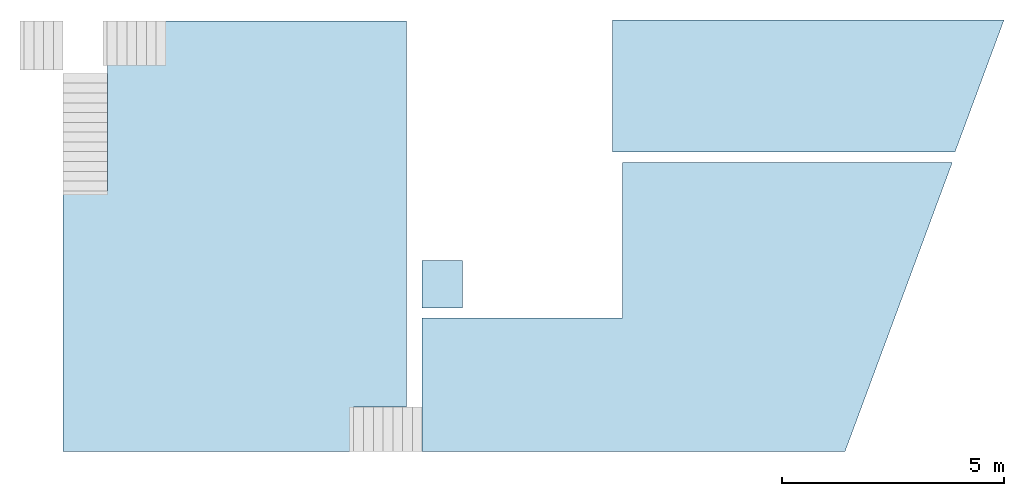
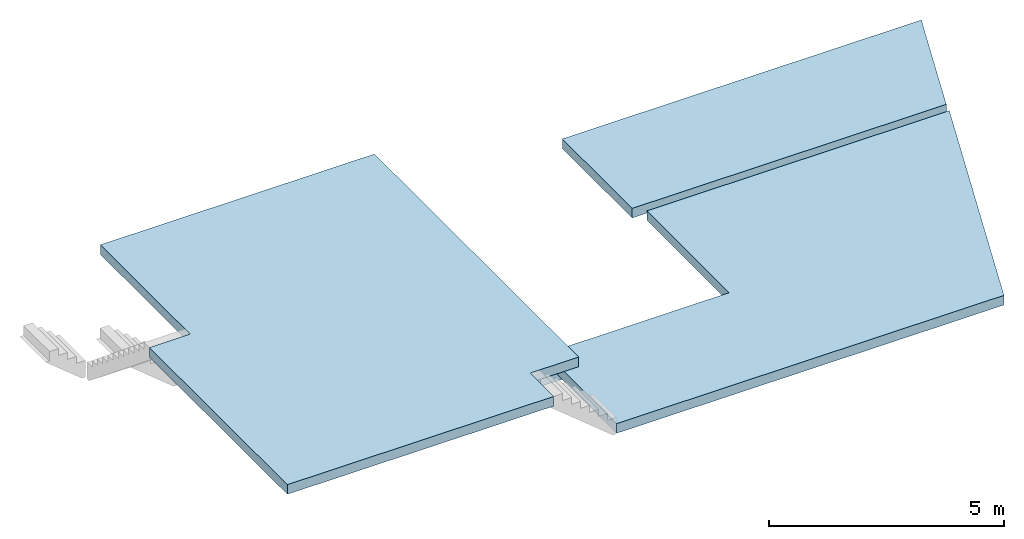
# One storey, part 1 of 2: 4 slabs.
"""IFC4 building model written with IfcOpenShell, lengths in metres."""

from ifc_helpers import new_model, entity, si_unit, converted_unit, frame, origin_with_axes, origin_2d_with_axis, place, context, subcontext, project, spatial, line, indexed_curve, outline, extrude, material, layer, layer_set, layer_usage, type_object, element, save


model = new_model("IFC4")

# Units and contexts
model_context = context("Model", 3, precision=1e-05, world=origin_with_axes())
plan_context = context("Plan", 2, precision=1e-05, world=origin_2d_with_axis())
body_context = subcontext(model_context, "Body", "Model", "MODEL_VIEW")
ifc_project = project(units=[si_unit("VOLUMEUNIT", "CUBIC_METRE"), si_unit("LENGTHUNIT", "METRE"), converted_unit("PLANEANGLEUNIT", "degree", entity("IfcReal", 0.0174532925199433), si_unit("PLANEANGLEUNIT", "RADIAN"), dimensions=[0, 0, 0, 0, 0, 0, 0]), si_unit("AREAUNIT", "SQUARE_METRE")], contexts=[model_context, plan_context])

# Site, building, storey
site_placement = place(None, origin_with_axes())
site = spatial("IfcSite", under=ifc_project, at=site_placement)
building_placement = place(site_placement, origin_with_axes())
building = spatial("IfcBuilding", under=site, at=building_placement)
storey_placement = place(building_placement, frame((0.0, 0.0, 4.23999977111816), z_axis=(0.0, 0.0, 1.0), x_axis=(1.0, 0.0, 0.0)))
storey = spatial("IfcBuildingStorey", under=building, at=storey_placement, Name="First floor")

# Slabs
ifc_material = material(Name="Concrete")
ifc_layer = layer(ifc_material, 0.25, Name="Concrete slab")
ifc_layer_set = layer_set([ifc_layer], Name="solid slab 250")
ifc_layer_usage_1 = layer_usage(ifc_layer_set, "AXIS3", "POSITIVE", 0.0)
slab_type = type_object("IfcSlabType", Name="concrete slab", PredefinedType="FLOOR", material=ifc_layer_set)
slab_1_placement = place(storey_placement, frame((21.3532009124756, 5.47878217697144, -0.25), z_axis=(0.0, 0.0, 1.0), x_axis=(1.0, 0.0, 0.0)))
element("IfcSlab", 1, at=slab_1_placement, inside=storey, type_object=slab_type, material=ifc_layer_usage_1, Name="Slab", context=body_context, shape_type="SweptSolid", body=[
    extrude(outline(indexed_curve([(0.0, 0.0), (9.5367431640625e-07, 5.85999870300293), (1.00000143051147, 5.85999965667725), (1.00000190734863, 9.67499923706055), (7.72000503540039, 9.67499923706055), (7.72000312805176, 1.00000238418579), (6.53000164031982, 1.00000190734863), (6.53000068664551, 1.9073486328125e-06)], segments=[line(2, 1), line(1, 8), line(8, 7), line(7, 6), line(6, 5), line(5, 4), line(4, 3), line(3, 2)], self_intersect=False)), None, (0.0, 0.0, 1.0), 0.25),
])
ifc_layer_usage_2 = layer_usage(ifc_layer_set, "AXIS3", "POSITIVE", 0.0)
slab_2_placement = place(storey_placement, frame((29.4232025146484, 5.47878265380859, -1.49428129196167), z_axis=(0.0, 0.0, 1.0), x_axis=(1.0, 0.0, 0.0)))
element("IfcSlab", 2, at=slab_2_placement, inside=storey, type_object=slab_type, material=ifc_layer_usage_2, Name="Slab", context=body_context, shape_type="SweptSolid", body=[
    extrude(outline(indexed_curve([(0.0, 0.0), (9.5, 0.0), (11.9123725891113, 6.49999904632568), (0.0, 2.99999904632568), (4.50000190734863, 6.49999856948853), (4.49499988555908, 3.0049991607666)], segments=[line(1, 2), line(2, 3), line(3, 5), line(5, 6), line(6, 4), line(4, 1)], self_intersect=False)), None, (0.0, 0.0, 1.0), 0.25),
])
ifc_layer_usage_3 = layer_usage(ifc_layer_set, "AXIS3", "POSITIVE", 0.0)
slab_3_placement = place(storey_placement, frame((33.6932029724121, 12.2087802886963, -1.48999977111816), z_axis=(0.0, 0.0, 1.0), x_axis=(1.0, 0.0, 0.0)))
element("IfcSlab", 3, at=slab_3_placement, inside=storey, type_object=slab_type, material=ifc_layer_usage_3, Name="Slab", context=body_context, shape_type="SweptSolid", body=[
    extrude(outline(indexed_curve([(8.8033332824707, 2.97000503540039), (7.70106887817383, 0.0), (0.0, 0.0), (0.0, 2.97000217437744)], segments=[line(4, 1), line(1, 2), line(2, 3), line(3, 4)], self_intersect=False)), None, (0.0, 0.0, 1.0), 0.25),
])
ifc_layer_usage_4 = layer_usage(ifc_layer_set, "AXIS3", "POSITIVE", 0.0)
slab_4_placement = place(storey_placement, frame((29.4232025146484, 8.70878124237061, -2.23887372016906), z_axis=(0.0, 0.0, 1.0), x_axis=(1.0, 0.0, 0.0)))
element("IfcSlab", 4, at=slab_4_placement, inside=storey, type_object=slab_type, material=ifc_layer_usage_4, Name="Slab", context=body_context, shape_type="SweptSolid", body=[
    extrude(outline(indexed_curve([(0.899999618530273, 1.07000064849854), (0.899999618530273, 0.0), (0.0, 0.0), (0.0, 1.07000064849854)], segments=[line(3, 2), line(2, 1), line(1, 4), line(4, 3)], self_intersect=False)), None, (0.0, 0.0, 1.0), 0.25),
])

save(model, "model.ifc")
